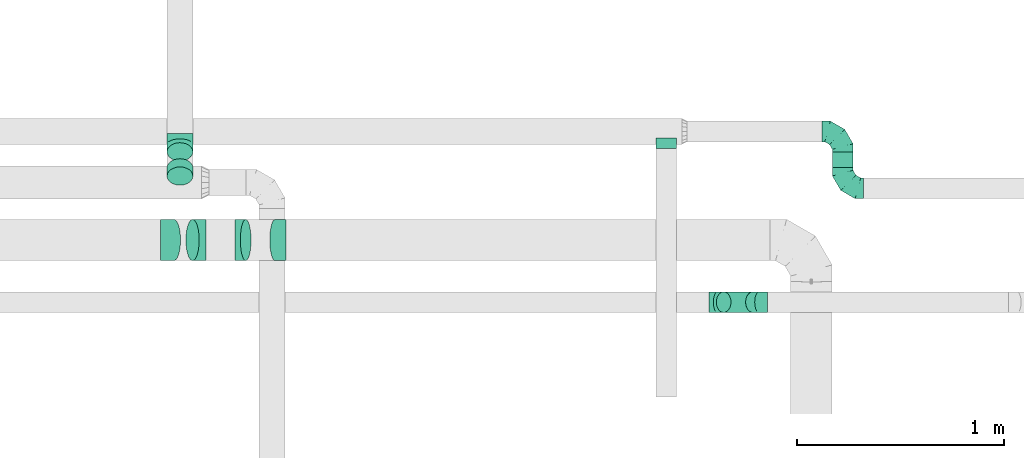
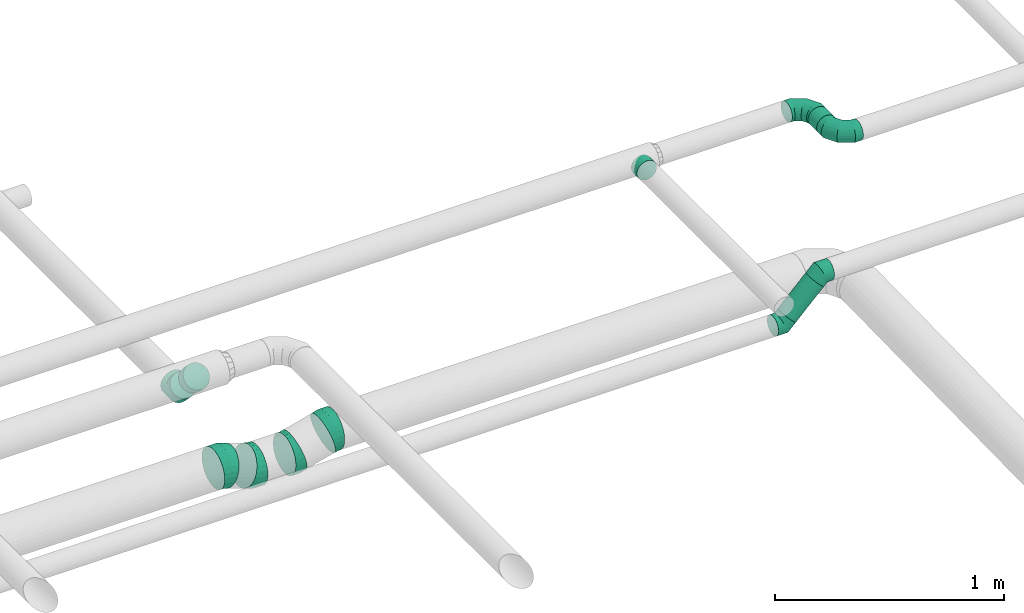
# One storey, part 21 of 60: 11 flow fittings, 2 flow segments.
"""IFC2X3 building model written with IfcOpenShell, lengths in millimetres."""

from ifc_helpers import new_model, entity, si_unit, converted_unit, derived_unit, direction, frame, origin, origin_2d_with_axis, place, context, subcontext, project, spatial, circle, extrude, faceted_brep, source, transform, mapped, material, type_object, type_shapes, element, save


model = new_model("IFC2X3")

# Units and contexts
model_context = context("Model", 3, precision=0.01, world=origin(), true_north=direction((6.12303176911189e-17, 1.0)))
body_context = subcontext(model_context, "Body", "Model", "MODEL_VIEW")
ifc_project = project(units=[si_unit("LENGTHUNIT", "METRE", prefix="MILLI"), si_unit("AREAUNIT", "SQUARE_METRE"), si_unit("VOLUMEUNIT", "CUBIC_METRE"), converted_unit("PLANEANGLEUNIT", "DEGREE", entity("IfcRatioMeasure", 0.0174532925199433), si_unit("PLANEANGLEUNIT", "RADIAN"), dimensions=[0, 0, 0, 0, 0, 0, 0]), si_unit("MASSUNIT", "GRAM", prefix="KILO"), derived_unit("MASSDENSITYUNIT", [(si_unit("MASSUNIT", "GRAM", prefix="KILO"), 1), (si_unit("LENGTHUNIT", "METRE"), -3)]), derived_unit("MOMENTOFINERTIAUNIT", [(si_unit("LENGTHUNIT", "METRE"), 4)]), si_unit("TIMEUNIT", "SECOND"), si_unit("FREQUENCYUNIT", "HERTZ"), si_unit("THERMODYNAMICTEMPERATUREUNIT", "DEGREE_CELSIUS"), derived_unit("THERMALTRANSMITTANCEUNIT", [(si_unit("MASSUNIT", "GRAM", prefix="KILO"), 1), (si_unit("THERMODYNAMICTEMPERATUREUNIT", "KELVIN"), -1), (si_unit("TIMEUNIT", "SECOND"), -3)]), derived_unit("VOLUMETRICFLOWRATEUNIT", [(si_unit("LENGTHUNIT", "METRE"), 3), (si_unit("TIMEUNIT", "SECOND"), -1)]), derived_unit("MASSFLOWRATEUNIT", [(si_unit("MASSUNIT", "GRAM", prefix="KILO"), 1), (si_unit("TIMEUNIT", "SECOND"), -1)]), derived_unit("ROTATIONALFREQUENCYUNIT", [(si_unit("TIMEUNIT", "SECOND"), -1)]), si_unit("ELECTRICCURRENTUNIT", "AMPERE"), si_unit("ELECTRICVOLTAGEUNIT", "VOLT"), si_unit("POWERUNIT", "WATT"), si_unit("FORCEUNIT", "NEWTON", prefix="KILO"), si_unit("ILLUMINANCEUNIT", "LUX"), si_unit("LUMINOUSFLUXUNIT", "LUMEN"), si_unit("LUMINOUSINTENSITYUNIT", "CANDELA"), derived_unit("USERDEFINED", [(si_unit("MASSUNIT", "GRAM", prefix="KILO"), -1), (si_unit("LENGTHUNIT", "METRE"), -2), (si_unit("TIMEUNIT", "SECOND"), 3), (si_unit("LUMINOUSFLUXUNIT", "LUMEN"), 1)]), derived_unit("LINEARVELOCITYUNIT", [(si_unit("LENGTHUNIT", "METRE"), 1), (si_unit("TIMEUNIT", "SECOND"), -1)]), si_unit("PRESSUREUNIT", "PASCAL"), derived_unit("USERDEFINED", [(si_unit("LENGTHUNIT", "METRE"), -2), (si_unit("MASSUNIT", "GRAM", prefix="KILO"), 1), (si_unit("TIMEUNIT", "SECOND"), -2)]), derived_unit("LINEARFORCEUNIT", [(si_unit("MASSUNIT", "GRAM", prefix="KILO"), 1), (si_unit("LENGTHUNIT", "METRE"), 1), (si_unit("TIMEUNIT", "SECOND"), -2), (si_unit("LENGTHUNIT", "METRE"), -1)]), derived_unit("PLANARFORCEUNIT", [(si_unit("MASSUNIT", "GRAM", prefix="KILO"), 1), (si_unit("LENGTHUNIT", "METRE"), 1), (si_unit("TIMEUNIT", "SECOND"), -2), (si_unit("LENGTHUNIT", "METRE"), -2)])], contexts=[model_context])

# Site, building, storey
site_placement = place(None, origin())
site = spatial("IfcSite", under=ifc_project, at=site_placement, CompositionType="ELEMENT")
building_placement = place(site_placement, origin())
building = spatial("IfcBuilding", under=site, at=building_placement, CompositionType="ELEMENT")
storey_placement = place(building_placement, frame((0.0, 0.0, 19800.0)))
storey = spatial("IfcBuildingStorey", under=building, at=storey_placement, CompositionType="ELEMENT", Elevation=19800.0)

# Flow segments
duct_segment_type = type_object("IfcDuctSegmentType", PredefinedType="NOTDEFINED")
flow_segment_1_placement = place(storey_placement, frame((31595.6, 10150.27, 3598.4)))
element("IfcFlowSegment", 1, at=flow_segment_1_placement, inside=storey, type_object=duct_segment_type, context=body_context, shape_type="SweptSolid", body=[
    extrude(circle(Radius=50.0, at=origin_2d_with_axis()), frame((51.6, 0.0, 51.6), z_axis=(0.0, 1.0, 0.0), x_axis=(-1.0, 0.0, 0.0)), (0.0, 0.0, 1.0), 74.6875000000426),
])
flow_segment_2_placement = place(storey_placement, frame((31034.99, 9448.58, 3192.34)))
element("IfcFlowSegment", 2, at=flow_segment_2_placement, inside=storey, type_object=duct_segment_type, context=body_context, shape_type="SweptSolid", body=[
    extrude(circle(Radius=50.0, at=origin_2d_with_axis()), frame((36.95, 51.6, 36.95), z_axis=(0.707106781186554, 0.0, 0.707106781186541), x_axis=(0.0, -1.0, 0.0)), (0.0, 0.0, 1.0), 200.000000000067),
])

# Flow fittings
ifc_material = material()
duct_fitting_type_1 = type_object("IfcDuctFittingType", PredefinedType="NOTDEFINED", material=ifc_material)
shared_shape_1 = source(origin(), body_context, "Body", "Brep", [
    faceted_brep([(-100.0, 0.0, -50.0), (-100.0, -12.94, -48.3), (-100.0, -25.0, -43.3), (-100.0, -35.36, -35.36), (-100.0, -43.3, -25.0), (-100.0, -48.3, -12.94), (-100.0, -50.0, 0.0), (-100.0, -48.3, 12.94), (-100.0, -43.3, 25.0), (-100.0, -35.36, 35.36), (-100.0, -25.0, 43.3), (-100.0, -12.94, 48.3), (-100.0, 0.0, 50.0), (-100.0, 12.94, 48.3), (-100.0, 25.0, 43.3), (-100.0, 35.36, 35.36), (-100.0, 43.3, 25.0), (-100.0, 48.3, 12.94), (-100.0, 50.0, 0.0), (-100.0, 48.3, -12.94), (-100.0, 43.3, -25.0), (-100.0, 35.36, -35.36), (-100.0, 25.0, -43.3), (-100.0, 12.94, -48.3), (-76.67, 12.94, 48.3), (-79.9, 25.0, 43.3), (-73.21, 0.0, 50.0), (-82.68, 35.36, 35.36), (-86.15, 48.3, 12.94), (-86.6, 50.0, 0.0), (-84.81, 43.3, 25.0), (-84.81, 43.3, -25.0), (-82.68, 35.36, -35.36), (-86.15, 48.3, -12.94), (-76.67, 12.94, -48.3), (-73.21, 0.0, -50.0), (-79.9, 25.0, -43.3), (-69.74, -12.94, -48.3), (-66.51, -25.0, -43.3), (-63.73, -35.36, -35.36), (-61.6, -43.3, -25.0), (-60.26, -48.3, -12.94), (-59.81, -50.0, 0.0), (-60.26, -48.3, 12.94), (-61.6, -43.3, 25.0), (-63.73, -35.36, 35.36), (-66.51, -25.0, 43.3), (-69.74, -12.94, 48.3), (-36.27, 36.27, 48.3), (-45.1, 45.1, 43.3), (-26.79, 26.79, 50.0), (-52.68, 52.68, 35.36), (-58.49, 58.49, 25.0), (-62.15, 62.15, 12.94), (-63.4, 63.4, 0.0), (-62.15, 62.15, -12.94), (-58.49, 58.49, -25.0), (-52.68, 52.68, -35.36), (-36.27, 36.27, -48.3), (-26.79, 26.79, -50.0), (-45.1, 45.1, -43.3), (-17.32, 17.32, -48.3), (-8.49, 8.49, -43.3), (-0.91, 0.91, -35.36), (4.9, -4.9, -25.0), (8.56, -8.56, -12.94), (9.81, -9.81, 0.0), (8.56, -8.56, 12.94), (4.9, -4.9, 25.0), (-0.91, 0.91, 35.36), (-8.49, 8.49, 43.3), (-17.32, 17.32, 48.3), (-12.94, 76.67, 48.3), (-25.0, 79.9, 43.3), (0.0, 73.21, 50.0), (-35.36, 82.68, 35.36), (-43.3, 84.81, 25.0), (-48.3, 86.15, 12.94), (-50.0, 86.6, 0.0), (-48.3, 86.15, -12.94), (-43.3, 84.81, -25.0), (-35.36, 82.68, -35.36), (-12.94, 76.67, -48.3), (0.0, 73.21, -50.0), (-25.0, 79.9, -43.3), (12.94, 69.74, -48.3), (25.0, 66.51, -43.3), (35.36, 63.73, -35.36), (43.3, 61.6, -25.0), (48.3, 60.26, -12.94), (50.0, 59.81, 0.0), (48.3, 60.26, 12.94), (43.3, 61.6, 25.0), (35.36, 63.73, 35.36), (25.0, 66.51, 43.3), (12.94, 69.74, 48.3), (-12.94, 100.0, -48.3), (-25.0, 100.0, -43.3), (-35.36, 100.0, -35.36), (-43.3, 100.0, -25.0), (-48.3, 100.0, -12.94), (-50.0, 100.0, 0.0), (-48.3, 100.0, 12.94), (-43.3, 100.0, 25.0), (-35.36, 100.0, 35.36), (-25.0, 100.0, 43.3), (-12.94, 100.0, 48.3), (0.0, 100.0, 50.0), (12.94, 100.0, 48.3), (25.0, 100.0, 43.3), (35.36, 100.0, 35.36), (43.3, 100.0, 25.0), (48.3, 100.0, 12.94), (50.0, 100.0, 0.0), (48.3, 100.0, -12.94), (43.3, 100.0, -25.0), (35.36, 100.0, -35.36), (25.0, 100.0, -43.3), (12.94, 100.0, -48.3), (0.0, 100.0, -50.0)], [[[0, 1, 2, 3, 4, 5, 6, 7, 8, 9, 10, 11, 12, 13, 14, 15, 16, 17, 18, 19, 20, 21, 22, 23]], [[24, 25, 14, 13]], [[26, 24, 13, 12]], [[14, 25, 27, 15]], [[28, 29, 18, 17]], [[30, 28, 17, 16]], [[15, 27, 30, 16]], [[20, 31, 32, 21]], [[33, 31, 20, 19]], [[18, 29, 33, 19]], [[34, 35, 0, 23]], [[36, 34, 23, 22]], [[32, 36, 22, 21]], [[2, 1, 37, 38]], [[3, 2, 38, 39]], [[0, 35, 37, 1]], [[5, 4, 40, 41]], [[6, 5, 41, 42]], [[3, 39, 40, 4]], [[6, 42, 43, 7]], [[7, 43, 44, 8]], [[8, 44, 45, 9]], [[10, 46, 47, 11]], [[11, 47, 26, 12]], [[10, 9, 45, 46]], [[48, 49, 25, 24]], [[50, 48, 24, 26]], [[27, 25, 49, 51]], [[52, 53, 28, 30]], [[51, 52, 30, 27]], [[29, 28, 53, 54]], [[55, 56, 31, 33]], [[54, 55, 33, 29]], [[57, 32, 31, 56]], [[58, 59, 35, 34]], [[60, 58, 34, 36]], [[57, 60, 36, 32]], [[37, 35, 59, 61]], [[38, 37, 61, 62]], [[39, 38, 62, 63]], [[41, 40, 64, 65]], [[42, 41, 65, 66]], [[63, 64, 40, 39]], [[43, 42, 66, 67]], [[44, 43, 67, 68]], [[68, 69, 45, 44]], [[46, 45, 69, 70]], [[47, 46, 70, 71]], [[26, 47, 71, 50]], [[72, 73, 49, 48]], [[74, 72, 48, 50]], [[51, 49, 73, 75]], [[76, 77, 53, 52]], [[75, 76, 52, 51]], [[54, 53, 77, 78]], [[79, 80, 56, 55]], [[78, 79, 55, 54]], [[81, 57, 56, 80]], [[82, 83, 59, 58]], [[84, 82, 58, 60]], [[81, 84, 60, 57]], [[61, 59, 83, 85]], [[62, 61, 85, 86]], [[63, 62, 86, 87]], [[65, 64, 88, 89]], [[66, 65, 89, 90]], [[87, 88, 64, 63]], [[67, 66, 90, 91]], [[68, 67, 91, 92]], [[92, 93, 69, 68]], [[70, 69, 93, 94]], [[71, 70, 94, 95]], [[50, 71, 95, 74]], [[96, 97, 98, 99, 100, 101, 102, 103, 104, 105, 106, 107, 108, 109, 110, 111, 112, 113, 114, 115, 116, 117, 118, 119]], [[72, 74, 107, 106]], [[73, 72, 106, 105]], [[75, 73, 105, 104]], [[77, 76, 103, 102]], [[78, 77, 102, 101]], [[75, 104, 103, 76]], [[78, 101, 100, 79]], [[79, 100, 99, 80]], [[80, 99, 98, 81]], [[96, 119, 83, 82]], [[97, 96, 82, 84]], [[84, 81, 98, 97]], [[83, 119, 118, 85]], [[85, 118, 117, 86]], [[86, 117, 116, 87]], [[88, 115, 114, 89]], [[89, 114, 113, 90]], [[87, 116, 115, 88]], [[91, 90, 113, 112]], [[92, 91, 112, 111]], [[93, 92, 111, 110]], [[95, 94, 109, 108]], [[74, 95, 108, 107]], [[110, 109, 94, 93]]]),
])
type_shapes(duct_fitting_type_1, [shared_shape_1])
for number, where, z_axis, x_axis in (
    (3, (31647.19, 10324.96, 3650.0), (0.0, 0.0, 1.0), (0.0, 1.0, 0.0)),
    (4, (31647.19, 10050.27, 3650.0), (0.0, 0.0, 1.0), (0.0, -1.0, 0.0)),
):
    element("IfcFlowFitting", number, at=place(storey_placement, frame(where, z_axis=z_axis, x_axis=x_axis)), inside=storey, type_object=duct_fitting_type_1, material=ifc_material, context=body_context, shape_type="MappedRepresentation", body=[
        mapped(shared_shape_1, transform((0.0, 0.0, 0.0), scale=1.0)),
    ])
duct_fitting_type_2 = type_object("IfcDuctFittingType", PredefinedType="NOTDEFINED", material=ifc_material)
shared_shape_2 = source(origin(), body_context, "Body", "Brep", [
    faceted_brep([(-51.78, 0.0, -62.5), (-51.78, -16.18, -60.37), (-51.78, -31.25, -54.13), (-51.78, -44.19, -44.19), (-51.78, -54.13, -31.25), (-51.78, -60.37, -16.18), (-51.78, -62.5, 0.0), (-51.78, -60.37, 16.18), (-51.78, -54.13, 31.25), (-51.78, -44.19, 44.19), (-51.78, -31.25, 54.13), (-51.78, -16.18, 60.37), (-51.78, 0.0, 62.5), (-51.78, 16.18, 60.37), (-51.78, 31.25, 54.13), (-51.78, 44.19, 44.19), (-51.78, 54.13, 31.25), (-51.78, 60.37, 16.18), (-51.78, 62.5, 0.0), (-51.78, 60.37, -16.18), (-51.78, 54.13, -31.25), (-51.78, 44.19, -44.19), (-51.78, 31.25, -54.13), (-51.78, 16.18, -60.37), (-6.7, 16.18, 60.37), (-12.94, 31.25, 54.13), (0.0, 0.0, 62.5), (-18.31, 44.19, 44.19), (-22.42, 54.13, 31.25), (-25.01, 60.37, 16.18), (-25.89, 62.5, 0.0), (-25.01, 60.37, -16.18), (-22.42, 54.13, -31.25), (-18.31, 44.19, -44.19), (-6.7, 16.18, -60.37), (0.0, 0.0, -62.5), (-12.94, 31.25, -54.13), (6.7, -16.18, -60.37), (12.94, -31.25, -54.13), (18.31, -44.19, -44.19), (22.42, -54.13, -31.25), (25.01, -60.37, -16.18), (25.89, -62.5, 0.0), (25.01, -60.37, 16.18), (22.42, -54.13, 31.25), (18.31, -44.19, 44.19), (12.94, -31.25, 54.13), (6.7, -16.18, 60.37), (25.17, 48.05, 60.37), (14.51, 58.71, 54.13), (36.61, 36.61, 62.5), (5.36, 67.86, 44.19), (-1.66, 74.88, 31.25), (-6.08, 79.3, 16.18), (-7.58, 80.81, 0.0), (-6.08, 79.3, -16.18), (-1.66, 74.88, -31.25), (5.36, 67.86, -44.19), (14.51, 58.71, -54.13), (25.17, 48.05, -60.37), (36.61, 36.61, -62.5), (48.05, 25.17, -60.37), (58.71, 14.51, -54.13), (67.86, 5.36, -44.19), (74.88, -1.66, -31.25), (79.3, -6.08, -16.18), (80.81, -7.58, 0.0), (79.3, -6.08, 16.18), (74.88, -1.66, 31.25), (67.86, 5.36, 44.19), (58.71, 14.51, 54.13), (48.05, 25.17, 60.37)], [[[0, 1, 2, 3, 4, 5, 6, 7, 8, 9, 10, 11, 12, 13, 14, 15, 16, 17, 18, 19, 20, 21, 22, 23]], [[24, 25, 14, 13]], [[26, 24, 13, 12]], [[27, 15, 14, 25]], [[28, 29, 17, 16]], [[28, 16, 15, 27]], [[30, 18, 17, 29]], [[31, 32, 20, 19]], [[30, 31, 19, 18]], [[21, 20, 32, 33]], [[34, 35, 0, 23]], [[36, 34, 23, 22]], [[33, 36, 22, 21]], [[1, 0, 35, 37]], [[2, 1, 37, 38]], [[38, 39, 3, 2]], [[5, 4, 40, 41]], [[6, 5, 41, 42]], [[39, 40, 4, 3]], [[6, 42, 43, 7]], [[7, 43, 44, 8]], [[8, 44, 45, 9]], [[9, 45, 46, 10]], [[10, 46, 47, 11]], [[26, 12, 11, 47]], [[48, 49, 25, 24]], [[50, 48, 24, 26]], [[27, 25, 49, 51]], [[29, 28, 52, 53]], [[30, 29, 53, 54]], [[51, 52, 28, 27]], [[30, 54, 55, 31]], [[31, 55, 56, 32]], [[57, 33, 32, 56]], [[36, 58, 59, 34]], [[34, 59, 60, 35]], [[58, 36, 33, 57]], [[35, 60, 61, 37]], [[37, 61, 62, 38]], [[63, 39, 38, 62]], [[40, 64, 65, 41]], [[41, 65, 66, 42]], [[64, 40, 39, 63]], [[43, 42, 66, 67]], [[44, 43, 67, 68]], [[68, 69, 45, 44]], [[47, 46, 70, 71]], [[26, 47, 71, 50]], [[69, 70, 46, 45]], [[59, 58, 57, 56, 55, 54, 53, 52, 51, 49, 48, 50, 71, 70, 69, 68, 67, 66, 65, 64, 63, 62, 61, 60]]]),
])
type_shapes(duct_fitting_type_2, [shared_shape_2])
flow_fitting_1_placement = place(storey_placement, frame((28445.25, 10263.08, 3300.32), z_axis=(-1.0, 0.0, 0.0), x_axis=(0.0, -1.0, 0.0)))
element("IfcFlowFitting", 5, at=flow_fitting_1_placement, inside=storey, type_object=duct_fitting_type_2, material=ifc_material, context=body_context, shape_type="MappedRepresentation", body=[
    mapped(shared_shape_2, transform((0.0, 0.0, 0.0), scale=1.0)),
])
duct_fitting_type_3 = type_object("IfcDuctFittingType", PredefinedType="NOTDEFINED", material=ifc_material)
shared_shape_3 = source(origin(), body_context, "Body", "Brep", [
    faceted_brep([(-41.42, 0.0, -50.0), (-41.42, -12.94, -48.3), (-41.42, -25.0, -43.3), (-41.42, -35.36, -35.36), (-41.42, -43.3, -25.0), (-41.42, -48.3, -12.94), (-41.42, -50.0, 0.0), (-41.42, -48.3, 12.94), (-41.42, -43.3, 25.0), (-41.42, -35.36, 35.36), (-41.42, -25.0, 43.3), (-41.42, -12.94, 48.3), (-41.42, 0.0, 50.0), (-41.42, 12.94, 48.3), (-41.42, 25.0, 43.3), (-41.42, 35.36, 35.36), (-41.42, 43.3, 25.0), (-41.42, 48.3, 12.94), (-41.42, 50.0, 0.0), (-41.42, 48.3, -12.94), (-41.42, 43.3, -25.0), (-41.42, 35.36, -35.36), (-41.42, 25.0, -43.3), (-41.42, 12.94, -48.3), (-5.36, 12.94, 48.3), (-10.36, 25.0, 43.3), (0.0, 0.0, 50.0), (-14.64, 35.36, 35.36), (-20.0, 48.3, 12.94), (-20.71, 50.0, 0.0), (-17.94, 43.3, 25.0), (-17.94, 43.3, -25.0), (-14.64, 35.36, -35.36), (-20.0, 48.3, -12.94), (-5.36, 12.94, -48.3), (0.0, 0.0, -50.0), (-10.36, 25.0, -43.3), (5.36, -12.94, -48.3), (10.36, -25.0, -43.3), (14.64, -35.36, -35.36), (17.94, -43.3, -25.0), (20.0, -48.3, -12.94), (20.71, -50.0, 0.0), (20.0, -48.3, 12.94), (17.94, -43.3, 25.0), (14.64, -35.36, 35.36), (10.36, -25.0, 43.3), (5.36, -12.94, 48.3), (29.29, 29.29, 50.0), (20.14, 38.44, 48.3), (11.61, 46.97, 43.3), (4.29, 54.29, 35.36), (-1.33, 59.91, 25.0), (-4.86, 63.44, 12.94), (-6.07, 64.64, 0.0), (-4.86, 63.44, -12.94), (-1.33, 59.91, -25.0), (4.29, 54.29, -35.36), (11.61, 46.97, -43.3), (20.14, 38.44, -48.3), (29.29, 29.29, -50.0), (38.44, 20.14, -48.3), (46.97, 11.61, -43.3), (54.29, 4.29, -35.36), (59.91, -1.33, -25.0), (63.44, -4.86, -12.94), (64.64, -6.07, 0.0), (63.44, -4.86, 12.94), (59.91, -1.33, 25.0), (54.29, 4.29, 35.36), (46.97, 11.61, 43.3), (38.44, 20.14, 48.3)], [[[0, 1, 2, 3, 4, 5, 6, 7, 8, 9, 10, 11, 12, 13, 14, 15, 16, 17, 18, 19, 20, 21, 22, 23]], [[24, 25, 14, 13]], [[26, 24, 13, 12]], [[14, 25, 27, 15]], [[28, 29, 18, 17]], [[30, 28, 17, 16]], [[16, 15, 27, 30]], [[20, 31, 32, 21]], [[33, 31, 20, 19]], [[18, 29, 33, 19]], [[34, 35, 0, 23]], [[36, 34, 23, 22]], [[32, 36, 22, 21]], [[1, 0, 35, 37]], [[2, 1, 37, 38]], [[38, 39, 3, 2]], [[5, 4, 40, 41]], [[6, 5, 41, 42]], [[39, 40, 4, 3]], [[6, 42, 43, 7]], [[7, 43, 44, 8]], [[8, 44, 45, 9]], [[9, 45, 46, 10]], [[10, 46, 47, 11]], [[26, 12, 11, 47]], [[24, 26, 48, 49]], [[25, 24, 49, 50]], [[27, 25, 50, 51]], [[28, 30, 52, 53]], [[29, 28, 53, 54]], [[27, 51, 52, 30]], [[29, 54, 55, 33]], [[33, 55, 56, 31]], [[31, 56, 57, 32]], [[36, 58, 59, 34]], [[34, 59, 60, 35]], [[36, 32, 57, 58]], [[61, 62, 38, 37]], [[60, 61, 37, 35]], [[63, 39, 38, 62]], [[40, 64, 65, 41]], [[41, 65, 66, 42]], [[64, 40, 39, 63]], [[43, 42, 66, 67]], [[44, 43, 67, 68]], [[68, 69, 45, 44]], [[47, 46, 70, 71]], [[26, 47, 71, 48]], [[69, 70, 46, 45]], [[59, 58, 57, 56, 55, 54, 53, 52, 51, 50, 49, 48, 71, 70, 69, 68, 67, 66, 65, 64, 63, 62, 61, 60]]]),
])
type_shapes(duct_fitting_type_3, [shared_shape_3])
for number, where, z_axis, x_axis in (
    (6, (31242.65, 9500.18, 3400.0), (0.0, 1.0, 0.0), (0.707106781186493, 0.0, 0.707106781186602)),
    (7, (31042.65, 9500.18, 3200.0), (0.0, 1.0, 0.0), (-0.707106781186493, 0.0, -0.707106781186602)),
):
    element("IfcFlowFitting", number, at=place(storey_placement, frame(where, z_axis=z_axis, x_axis=x_axis)), inside=storey, type_object=duct_fitting_type_3, material=ifc_material, context=body_context, shape_type="MappedRepresentation", body=[
        mapped(shared_shape_3, transform((0.0, 0.0, 0.0), scale=1.0)),
    ])
duct_fitting_type_4 = type_object("IfcDuctFittingType", PredefinedType="NOTDEFINED", material=ifc_material)
shared_shape_4 = source(origin(), body_context, "Body", "Brep", [
    faceted_brep([(20.0, 12.94, -48.3), (20.0, 25.0, -43.3), (20.0, 35.36, -35.36), (20.0, 43.3, -25.0), (20.0, 48.3, -12.94), (20.0, 50.0, 0.0), (20.0, 48.3, 12.94), (20.0, 43.3, 25.0), (20.0, 35.36, 35.36), (20.0, 25.0, 43.3), (20.0, 12.94, 48.3), (20.0, 0.0, 50.0), (20.0, -12.94, 48.3), (20.0, -25.0, 43.3), (20.0, -35.36, 35.36), (20.0, -43.3, 25.0), (20.0, -48.3, 12.94), (20.0, -50.0, 0.0), (20.0, -48.3, -12.94), (20.0, -43.3, -25.0), (20.0, -35.36, -35.36), (20.0, -25.0, -43.3), (20.0, -12.94, -48.3), (20.0, 0.0, -50.0), (0.0, 0.0, 50.0), (0.0, 12.94, 48.3), (-31.1, 12.94, 48.3), (-31.1, 0.0, 50.0), (0.0, 25.0, 43.3), (-31.1, 25.0, 43.3), (0.0, 35.36, 35.36), (-31.1, 35.36, 35.36), (0.0, 43.3, 25.0), (0.0, 48.3, 12.94), (-31.1, 48.3, 12.94), (-31.1, 43.3, 25.0), (0.0, 50.0, 0.0), (-31.1, 50.0, 0.0), (0.0, 48.3, -12.94), (-31.1, 48.3, -12.94), (0.0, 43.3, -25.0), (-31.1, 43.3, -25.0), (0.0, 35.36, -35.36), (-31.1, 35.36, -35.36), (0.0, 25.0, -43.3), (0.0, 12.94, -48.3), (-31.1, 12.94, -48.3), (-31.1, 25.0, -43.3), (0.0, 0.0, -50.0), (-31.1, 0.0, -50.0), (0.0, -12.94, -48.3), (-31.1, -12.94, -48.3), (0.0, -25.0, -43.3), (-31.1, -25.0, -43.3), (0.0, -35.36, -35.36), (-31.1, -35.36, -35.36), (0.0, -43.3, -25.0), (0.0, -48.3, -12.94), (-31.1, -48.3, -12.94), (-31.1, -43.3, -25.0), (0.0, -50.0, 0.0), (-31.1, -50.0, 0.0), (0.0, -48.3, 12.94), (-31.1, -48.3, 12.94), (0.0, -43.3, 25.0), (-31.1, -43.3, 25.0), (0.0, -35.36, 35.36), (-31.1, -35.36, 35.36), (0.0, -25.0, 43.3), (0.0, -12.94, 48.3), (-31.1, -12.94, 48.3), (-31.1, -25.0, 43.3)], [[[0, 1, 2, 3, 4, 5, 6, 7, 8, 9, 10, 11, 12, 13, 14, 15, 16, 17, 18, 19, 20, 21, 22, 23]], [[24, 11, 10, 25, 26, 27]], [[25, 10, 9, 28, 29, 26]], [[28, 9, 8, 30, 31, 29]], [[32, 7, 6, 33, 34, 35]], [[33, 6, 5, 36, 37, 34]], [[30, 8, 7, 32, 35, 31]], [[36, 5, 4, 38, 39, 37]], [[38, 4, 3, 40, 41, 39]], [[40, 3, 2, 42, 43, 41]], [[44, 1, 0, 45, 46, 47]], [[45, 0, 23, 48, 49, 46]], [[42, 2, 1, 44, 47, 43]], [[48, 23, 22, 50, 51, 49]], [[50, 22, 21, 52, 53, 51]], [[52, 21, 20, 54, 55, 53]], [[56, 19, 18, 57, 58, 59]], [[57, 18, 17, 60, 61, 58]], [[54, 20, 19, 56, 59, 55]], [[60, 17, 16, 62, 63, 61]], [[62, 16, 15, 64, 65, 63]], [[64, 15, 14, 66, 67, 65]], [[68, 13, 12, 69, 70, 71]], [[69, 12, 11, 24, 27, 70]], [[66, 14, 13, 68, 71, 67]], [[49, 51, 53, 55, 59, 58, 61, 63, 65, 67, 71, 70, 27, 26, 29, 31, 35, 34, 37, 39, 41, 43, 47, 46]]]),
])
type_shapes(duct_fitting_type_4, [shared_shape_4])
flow_fitting_2_placement = place(storey_placement, frame((30794.32, 10262.46, 3650.0), z_axis=(0.0, 0.0, -1.0), x_axis=(0.0, -1.0, 0.0)))
element("IfcFlowFitting", 8, at=flow_fitting_2_placement, inside=storey, type_object=duct_fitting_type_4, material=ifc_material, context=body_context, shape_type="MappedRepresentation", body=[
    mapped(shared_shape_4, transform((0.0, 0.0, 0.0), scale=1.0)),
])
duct_fitting_type_5 = type_object("IfcDuctFittingType", PredefinedType="NOTDEFINED", material=ifc_material)
shared_shape_5 = source(origin(), body_context, "Body", "Brep", [
    faceted_brep([(20.0, 0.0, -62.5), (20.0, 16.18, -60.37), (20.0, 31.25, -54.13), (20.0, 44.19, -44.19), (20.0, 54.13, -31.25), (20.0, 60.37, -16.18), (20.0, 62.5, 0.0), (20.0, 60.37, 16.18), (20.0, 54.13, 31.25), (20.0, 44.19, 44.19), (20.0, 31.25, 54.13), (20.0, 16.18, 60.37), (20.0, 0.0, 62.5), (20.0, -16.18, 60.37), (20.0, -31.25, 54.13), (20.0, -44.19, 44.19), (20.0, -54.13, 31.25), (20.0, -60.37, 16.18), (20.0, -62.5, 0.0), (20.0, -60.37, -16.18), (20.0, -54.13, -31.25), (20.0, -44.19, -44.19), (20.0, -31.25, -54.13), (20.0, -16.18, -60.37), (0.0, 0.0, 62.5), (-36.16, 0.0, 62.5), (-36.16, -16.18, 60.37), (0.0, -16.18, 60.37), (-36.16, -31.25, 54.13), (0.0, -31.25, 54.13), (0.0, -44.19, 44.19), (-36.16, -44.19, 44.19), (0.0, -54.13, 31.25), (-36.16, -54.13, 31.25), (-36.16, -60.37, 16.18), (0.0, -60.37, 16.18), (-36.16, -62.5, 0.0), (0.0, -62.5, 0.0), (-36.16, -60.37, -16.18), (0.0, -60.37, -16.18), (-36.16, -54.13, -31.25), (0.0, -54.13, -31.25), (0.0, -44.19, -44.19), (-36.16, -44.19, -44.19), (0.0, -31.25, -54.13), (-36.16, -31.25, -54.13), (-36.16, -16.18, -60.37), (0.0, -16.18, -60.37), (-36.16, 0.0, -62.5), (0.0, 0.0, -62.5), (-36.16, 16.18, -60.37), (0.0, 16.18, -60.37), (-36.16, 31.25, -54.13), (0.0, 31.25, -54.13), (0.0, 44.19, -44.19), (-36.16, 44.19, -44.19), (0.0, 54.13, -31.25), (-36.16, 54.13, -31.25), (-36.16, 60.37, -16.18), (0.0, 60.37, -16.18), (-36.16, 62.5, 0.0), (0.0, 62.5, 0.0), (-36.16, 60.37, 16.18), (0.0, 60.37, 16.18), (-36.16, 54.13, 31.25), (0.0, 54.13, 31.25), (0.0, 44.19, 44.19), (-36.16, 44.19, 44.19), (0.0, 31.25, 54.13), (-36.16, 31.25, 54.13), (-36.16, 16.18, 60.37), (0.0, 16.18, 60.37)], [[[0, 1, 2, 3, 4, 5, 6, 7, 8, 9, 10, 11, 12, 13, 14, 15, 16, 17, 18, 19, 20, 21, 22, 23]], [[13, 12, 24, 25, 26, 27]], [[14, 13, 27, 26, 28, 29]], [[30, 15, 14, 29, 28, 31]], [[17, 16, 32, 33, 34, 35]], [[18, 17, 35, 34, 36, 37]], [[32, 16, 15, 30, 31, 33]], [[19, 18, 37, 36, 38, 39]], [[20, 19, 39, 38, 40, 41]], [[42, 21, 20, 41, 40, 43]], [[23, 22, 44, 45, 46, 47]], [[0, 23, 47, 46, 48, 49]], [[44, 22, 21, 42, 43, 45]], [[1, 0, 49, 48, 50, 51]], [[2, 1, 51, 50, 52, 53]], [[54, 3, 2, 53, 52, 55]], [[5, 4, 56, 57, 58, 59]], [[6, 5, 59, 58, 60, 61]], [[56, 4, 3, 54, 55, 57]], [[7, 6, 61, 60, 62, 63]], [[8, 7, 63, 62, 64, 65]], [[66, 9, 8, 65, 64, 67]], [[11, 10, 68, 69, 70, 71]], [[12, 11, 71, 70, 25, 24]], [[68, 10, 9, 66, 67, 69]], [[46, 45, 43, 40, 38, 36, 34, 33, 31, 28, 26, 25, 70, 69, 67, 64, 62, 60, 58, 57, 55, 52, 50, 48]]]),
])
type_shapes(duct_fitting_type_5, [shared_shape_5])
flow_fitting_3_placement = place(storey_placement, frame((28445.25, 10134.97, 3428.43), z_axis=(0.0, -0.707106781186609, -0.707106781186486), x_axis=(0.0, 0.70710678118647, -0.707106781186625)))
element("IfcFlowFitting", 9, at=flow_fitting_3_placement, inside=storey, type_object=duct_fitting_type_5, material=ifc_material, context=body_context, shape_type="MappedRepresentation", body=[
    mapped(shared_shape_5, transform((0.0, 0.0, 0.0), scale=1.0)),
])
duct_fitting_type_6 = type_object("IfcDuctFittingType", PredefinedType="NOTDEFINED", material=ifc_material)
shared_shape_6 = source(origin(), body_context, "Body", "Brep", [
    faceted_brep([(-26.33, 0.0, -100.0), (-26.33, -25.88, -96.59), (-26.33, -50.0, -86.6), (-26.33, -70.71, -70.71), (-26.33, -86.6, -50.0), (-26.33, -96.59, -25.88), (-26.33, -100.0, 0.0), (-26.33, -96.59, 25.88), (-26.33, -86.6, 50.0), (-26.33, -70.71, 70.71), (-26.33, -50.0, 86.6), (-26.33, -25.88, 96.59), (-26.33, 0.0, 100.0), (-26.33, 25.88, 96.59), (-26.33, 50.0, 86.6), (-26.33, 70.71, 70.71), (-26.33, 86.6, 50.0), (-26.33, 96.59, 25.88), (-26.33, 100.0, 0.0), (-26.33, 96.59, -25.88), (-26.33, 86.6, -50.0), (-26.33, 70.71, -70.71), (-26.33, 50.0, -86.6), (-26.33, 25.88, -96.59), (-3.41, 25.88, 96.59), (-6.58, 50.0, 86.6), (0.0, 0.0, 100.0), (-9.31, 70.71, 70.71), (-12.72, 96.59, 25.88), (-13.17, 100.0, 0.0), (-11.4, 86.6, 50.0), (-11.4, 86.6, -50.0), (-9.31, 70.71, -70.71), (-12.72, 96.59, -25.88), (-3.41, 25.88, -96.59), (0.0, 0.0, -100.0), (-6.58, 50.0, -86.6), (3.41, -25.88, -96.59), (6.58, -50.0, -86.6), (9.31, -70.71, -70.71), (11.4, -86.6, -50.0), (12.72, -96.59, -25.88), (13.17, -100.0, 0.0), (12.72, -96.59, 25.88), (11.4, -86.6, 50.0), (9.31, -70.71, 70.71), (6.58, -50.0, 86.6), (3.41, -25.88, 96.59), (25.43, 6.81, 100.0), (18.73, 31.81, 96.59), (12.49, 55.11, 86.6), (7.13, 75.12, 70.71), (3.02, 90.47, 50.0), (0.43, 100.12, 25.88), (-0.45, 103.41, 0.0), (0.43, 100.12, -25.88), (3.02, 90.47, -50.0), (7.13, 75.12, -70.71), (12.49, 55.11, -86.6), (18.73, 31.81, -96.59), (25.43, 6.81, -100.0), (32.13, -18.19, -96.59), (38.37, -41.48, -86.6), (43.73, -61.49, -70.71), (47.85, -76.84, -50.0), (50.43, -86.49, -25.88), (51.32, -89.78, 0.0), (50.43, -86.49, 25.88), (47.85, -76.84, 50.0), (43.73, -61.49, 70.71), (38.37, -41.48, 86.6), (32.13, -18.19, 96.59)], [[[0, 1, 2, 3, 4, 5, 6, 7, 8, 9, 10, 11, 12, 13, 14, 15, 16, 17, 18, 19, 20, 21, 22, 23]], [[24, 25, 14, 13]], [[26, 24, 13, 12]], [[14, 25, 27, 15]], [[28, 29, 18, 17]], [[30, 28, 17, 16]], [[15, 27, 30, 16]], [[20, 31, 32, 21]], [[33, 31, 20, 19]], [[18, 29, 33, 19]], [[34, 35, 0, 23]], [[36, 34, 23, 22]], [[32, 36, 22, 21]], [[2, 1, 37, 38]], [[3, 2, 38, 39]], [[0, 35, 37, 1]], [[5, 4, 40, 41]], [[6, 5, 41, 42]], [[39, 40, 4, 3]], [[6, 42, 43, 7]], [[7, 43, 44, 8]], [[8, 44, 45, 9]], [[10, 46, 47, 11]], [[11, 47, 26, 12]], [[9, 45, 46, 10]], [[24, 26, 48, 49]], [[25, 24, 49, 50]], [[27, 25, 50, 51]], [[28, 30, 52, 53]], [[29, 28, 53, 54]], [[27, 51, 52, 30]], [[29, 54, 55, 33]], [[33, 55, 56, 31]], [[31, 56, 57, 32]], [[36, 58, 59, 34]], [[34, 59, 60, 35]], [[36, 32, 57, 58]], [[35, 60, 61, 37]], [[37, 61, 62, 38]], [[38, 62, 63, 39]], [[40, 64, 65, 41]], [[41, 65, 66, 42]], [[39, 63, 64, 40]], [[43, 42, 66, 67]], [[44, 43, 67, 68]], [[45, 44, 68, 69]], [[47, 46, 70, 71]], [[26, 47, 71, 48]], [[69, 70, 46, 45]], [[59, 58, 57, 56, 55, 54, 53, 52, 51, 50, 49, 48, 71, 70, 69, 68, 67, 66, 65, 64, 63, 62, 61, 60]]]),
])
type_shapes(duct_fitting_type_6, [shared_shape_6])
for number, where, z_axis, x_axis in (
    (10, (28930.56, 9800.32, 3185.0), (0.0, -1.0, 0.0), (-1.0, 0.0, 0.0)),
    (11, (28737.37, 9800.32, 3133.24), (0.0, 1.0, 0.0), (-0.965925826289052, 0.0, -0.258819045102583)),
):
    element("IfcFlowFitting", number, at=place(storey_placement, frame(where, z_axis=z_axis, x_axis=x_axis)), inside=storey, type_object=duct_fitting_type_6, material=ifc_material, context=body_context, shape_type="MappedRepresentation", body=[
        mapped(shared_shape_6, transform((0.0, 0.0, 0.0), scale=1.0)),
    ])
duct_fitting_type_7 = type_object("IfcDuctFittingType", PredefinedType="NOTDEFINED", material=ifc_material)
shared_shape_7 = source(origin(), body_context, "Body", "Brep", [
    faceted_brep([(-32.95, 0.0, -100.0), (-32.95, -25.88, -96.59), (-32.95, -50.0, -86.6), (-32.95, -70.71, -70.71), (-32.95, -86.6, -50.0), (-32.95, -96.59, -25.88), (-32.95, -100.0, 0.0), (-32.95, -96.59, 25.88), (-32.95, -86.6, 50.0), (-32.95, -70.71, 70.71), (-32.95, -50.0, 86.6), (-32.95, -25.88, 96.59), (-32.95, 0.0, 100.0), (-32.95, 25.88, 96.59), (-32.95, 50.0, 86.6), (-32.95, 70.71, 70.71), (-32.95, 86.6, 50.0), (-32.95, 96.59, 25.88), (-32.95, 100.0, 0.0), (-32.95, 96.59, -25.88), (-32.95, 86.6, -50.0), (-32.95, 70.71, -70.71), (-32.95, 50.0, -86.6), (-32.95, 25.88, -96.59), (-4.26, 25.88, 96.59), (-8.24, 50.0, 86.6), (0.0, 0.0, 100.0), (-11.65, 70.71, 70.71), (-15.92, 96.59, 25.88), (-16.48, 100.0, 0.0), (-14.27, 86.6, 50.0), (-14.27, 86.6, -50.0), (-11.65, 70.71, -70.71), (-15.92, 96.59, -25.88), (-4.26, 25.88, -96.59), (0.0, 0.0, -100.0), (-8.24, 50.0, -86.6), (4.26, -25.88, -96.59), (8.24, -50.0, -86.6), (11.65, -70.71, -70.71), (14.27, -86.6, -50.0), (15.92, -96.59, -25.88), (16.48, -100.0, 0.0), (15.92, -96.59, 25.88), (14.27, -86.6, 50.0), (11.65, -70.71, 70.71), (8.24, -50.0, 86.6), (4.26, -25.88, 96.59), (31.21, 10.57, 100.0), (22.91, 35.09, 96.59), (15.17, 57.93, 86.6), (8.53, 77.55, 70.71), (3.43, 92.6, 50.0), (0.22, 102.06, 25.88), (-0.87, 105.29, 0.0), (0.22, 102.06, -25.88), (3.43, 92.6, -50.0), (8.53, 77.55, -70.71), (15.17, 57.93, -86.6), (22.91, 35.09, -96.59), (31.21, 10.57, -100.0), (39.52, -13.94, -96.59), (47.25, -36.78, -86.6), (53.9, -56.4, -70.71), (62.2, -80.91, -25.88), (63.29, -84.14, 0.0), (59.0, -71.45, -50.0), (62.2, -80.91, 25.88), (59.0, -71.45, 50.0), (53.9, -56.4, 70.71), (47.25, -36.78, 86.6), (39.52, -13.94, 96.59)], [[[0, 1, 2, 3, 4, 5, 6, 7, 8, 9, 10, 11, 12, 13, 14, 15, 16, 17, 18, 19, 20, 21, 22, 23]], [[24, 25, 14, 13]], [[26, 24, 13, 12]], [[14, 25, 27, 15]], [[28, 29, 18, 17]], [[30, 28, 17, 16]], [[15, 27, 30, 16]], [[20, 31, 32, 21]], [[33, 31, 20, 19]], [[18, 29, 33, 19]], [[34, 35, 0, 23]], [[36, 34, 23, 22]], [[32, 36, 22, 21]], [[2, 1, 37, 38]], [[3, 2, 38, 39]], [[0, 35, 37, 1]], [[5, 4, 40, 41]], [[6, 5, 41, 42]], [[39, 40, 4, 3]], [[6, 42, 43, 7]], [[7, 43, 44, 8]], [[8, 44, 45, 9]], [[10, 46, 47, 11]], [[11, 47, 26, 12]], [[9, 45, 46, 10]], [[24, 26, 48, 49]], [[25, 24, 49, 50]], [[27, 25, 50, 51]], [[28, 30, 52, 53]], [[29, 28, 53, 54]], [[27, 51, 52, 30]], [[29, 54, 55, 33]], [[33, 55, 56, 31]], [[31, 56, 57, 32]], [[36, 58, 59, 34]], [[34, 59, 60, 35]], [[36, 32, 57, 58]], [[35, 60, 61, 37]], [[37, 61, 62, 38]], [[38, 62, 63, 39]], [[64, 65, 42, 41]], [[66, 64, 41, 40]], [[39, 63, 66, 40]], [[43, 42, 65, 67]], [[44, 43, 67, 68]], [[45, 44, 68, 69]], [[47, 46, 70, 71]], [[26, 47, 71, 48]], [[69, 70, 46, 45]], [[59, 58, 57, 56, 55, 54, 53, 52, 51, 50, 49, 48, 71, 70, 69, 68, 67, 65, 64, 66, 63, 62, 61, 60]]]),
])
type_shapes(duct_fitting_type_7, [shared_shape_7])
for number, where, z_axis, x_axis in (
    (12, (28384.56, 9800.32, 3185.0), (0.0, 1.0, 0.0), (1.0, 0.0, 0.0)),
    (13, (28537.37, 9800.32, 3133.24), (0.0, 1.0, 0.0), (-1.0, 0.0, 0.0)),
):
    element("IfcFlowFitting", number, at=place(storey_placement, frame(where, z_axis=z_axis, x_axis=x_axis)), inside=storey, type_object=duct_fitting_type_7, material=ifc_material, context=body_context, shape_type="MappedRepresentation", body=[
        mapped(shared_shape_7, transform((0.0, 0.0, 0.0), scale=1.0)),
    ])

save(model, "model.ifc")
